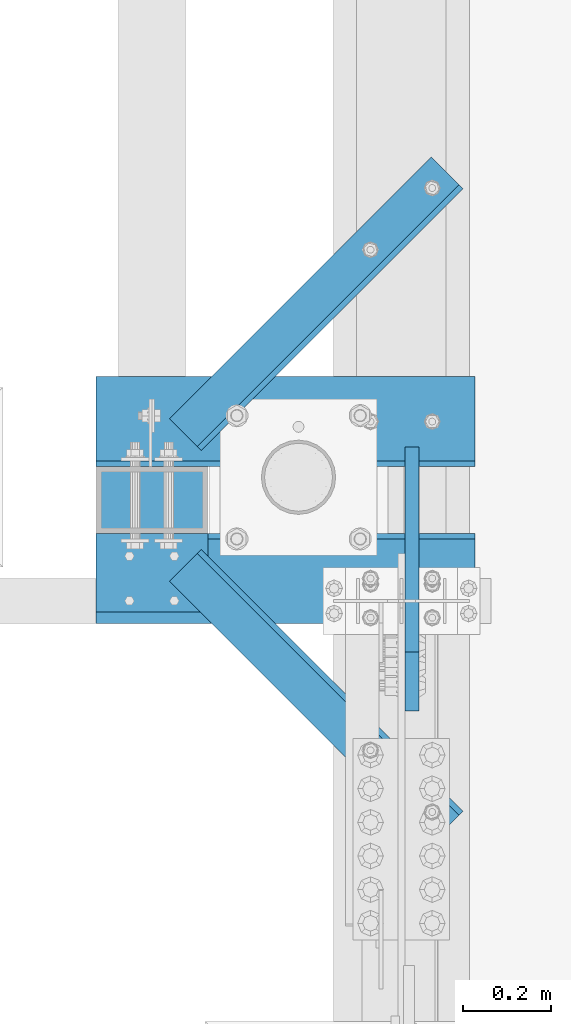
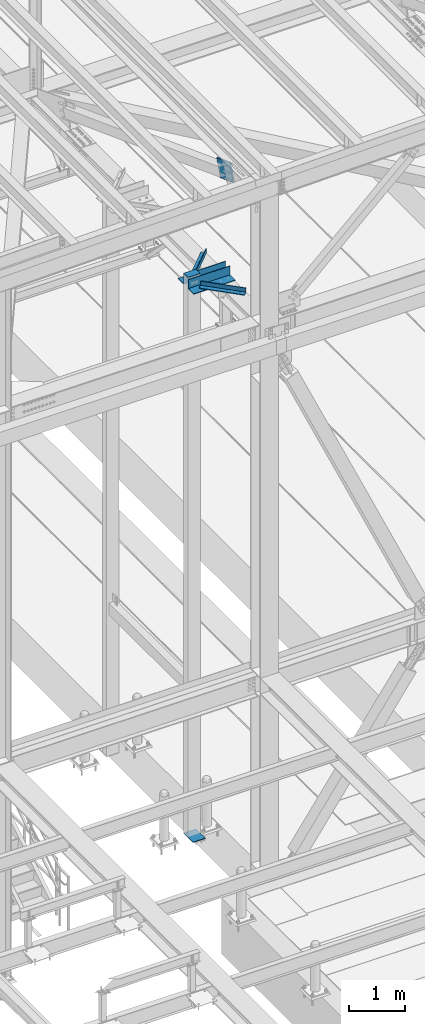
# One storey, part 2028 of 3843: 6 beams, 1 member, 6 elements without a shape of their own.
"""IFC2X3 building model written with IfcOpenShell, lengths in millimetres."""

from ifc_helpers import new_model, si_unit, frame, origin_with_axes, place, context, subcontext, project, spatial, faceted_brep, material, type_object, element, aggregate, save


model = new_model("IFC2X3")

# Units and contexts
model_context = context("Model", 3, precision=1e-05, world=origin_with_axes())
body_context = subcontext(model_context, "Body", "Model", "MODEL_VIEW")
ifc_project = project(units=[si_unit("LENGTHUNIT", "METRE", prefix="MILLI"), si_unit("AREAUNIT", "SQUARE_METRE"), si_unit("VOLUMEUNIT", "CUBIC_METRE"), si_unit("MASSUNIT", "GRAM", prefix="KILO"), si_unit("TIMEUNIT", "SECOND"), si_unit("PLANEANGLEUNIT", "RADIAN"), si_unit("SOLIDANGLEUNIT", "STERADIAN"), si_unit("THERMODYNAMICTEMPERATUREUNIT", "DEGREE_CELSIUS"), si_unit("LUMINOUSINTENSITYUNIT", "LUMEN")], contexts=[model_context])

# Site, building, storey
site_placement = place(None, origin_with_axes())
site = spatial("IfcSite", under=ifc_project, at=site_placement, CompositionType="ELEMENT")
building_placement = place(site_placement, origin_with_axes())
building = spatial("IfcBuilding", under=site, at=building_placement, Name="Undefined", CompositionType="ELEMENT")
storey_placement = place(building_placement, origin_with_axes())
storey = spatial("IfcBuildingStorey", under=building, at=storey_placement, Name="Undefined", CompositionType="ELEMENT", Elevation=0.0)

# Assembly, beam
assembly_1_placement = place(storey_placement, origin_with_axes())
assembly_1 = element("IfcElementAssembly", 1, at=assembly_1_placement, inside=storey, Name="ANGLE", AssemblyPlace="NOTDEFINED", PredefinedType="RIGID_FRAME")
ifc_material = material(Name="STEEL/A572-50")
beam_type_1 = type_object("IfcBeamType", Name="L4X4X1/2", PredefinedType="NOTDEFINED")
beam_1_placement = place(assembly_1_placement, frame((41573.4500000028, 27068.0579510283, 42474.3146705007), z_axis=(0.0, 0.0, 1.0), x_axis=(0.707106781186548, -0.707106781186548, 0.0)))
beam_1 = element("IfcBeam", 2, at=beam_1_placement, type_object=beam_type_1, material=ifc_material, Name="ANGLE", ObjectType="L4X4X1/2", context=body_context, shape_type="Brep", body=[
    faceted_brep([(0.0, 50.8000000000029, -50.8000000000029), (0.0, 50.8000000000029, 50.8000000000029), (838.199999993831, 50.7999999998719, 50.8000000000029), (838.199999993831, 50.7999999998719, -50.8000000000029), (0.0, 38.0999999999985, 50.8000000000029), (838.199999993823, 38.099999999904, 50.8000000000029), (0.0, 38.0999999999985, -38.0999999999985), (838.199999993823, 38.099999999904, -38.0999999999985), (0.0, -50.8000000000029, -38.1000000000058), (838.199999993823, -50.7999999998865, -38.0999999999985), (0.0, -50.8000000000029, -50.8000000000029), (838.199999993823, -50.7999999998865, -50.8000000000029)], [[[0, 1, 2, 3]], [[1, 4, 5, 2]], [[4, 6, 7, 5]], [[6, 8, 9, 7]], [[8, 10, 11, 9]], [[10, 0, 3, 11]], [[5, 7, 9, 11, 3, 2]], [[10, 8, 6, 4, 1, 0]]]),
])
aggregate(assembly_1, [beam_1])

assembly_2_placement = place(storey_placement, origin_with_axes())
assembly_2 = element("IfcElementAssembly", 3, at=assembly_2_placement, inside=storey, Name="ANGLE", AssemblyPlace="NOTDEFINED", PredefinedType="RIGID_FRAME")
beam_2_placement = place(assembly_2_placement, frame((42166.1469039905, 27956.8389529592, 42474.3146705007), z_axis=(0.0, 0.0, 1.0), x_axis=(-0.707106781186549, -0.707106781186546, 0.0)))
beam_2 = element("IfcBeam", 4, at=beam_2_placement, type_object=beam_type_1, material=ifc_material, Name="ANGLE", ObjectType="L4X4X1/2", context=body_context, shape_type="Brep", body=[
    faceted_brep([(0.0, 50.8000000000029, -50.8000000000029), (0.0, 50.8000000000029, 50.8000000000029), (838.199999993831, 50.7999999998719, 50.8000000000029), (838.199999993831, 50.7999999998719, -50.8000000000029), (0.0, 38.0999999999985, 50.8000000000029), (838.199999993823, 38.099999999904, 50.8000000000029), (0.0, 38.0999999999985, -38.0999999999985), (838.199999993823, 38.099999999904, -38.0999999999985), (0.0, -50.8000000000029, -38.1000000000058), (838.199999993823, -50.7999999998865, -38.0999999999985), (0.0, -50.8000000000029, -50.8000000000029), (838.199999993823, -50.7999999998865, -50.8000000000029)], [[[0, 1, 2, 3]], [[1, 4, 5, 2]], [[4, 6, 7, 5]], [[6, 8, 9, 7]], [[8, 10, 11, 9]], [[10, 0, 3, 11]], [[5, 7, 9, 11, 3, 2]], [[10, 8, 6, 4, 1, 0]]]),
])
aggregate(assembly_2, [beam_2])

assembly_3_placement = place(storey_placement, origin_with_axes())
assembly_3 = element("IfcElementAssembly", 5, at=assembly_3_placement, inside=storey, Name="POST", AssemblyPlace="NOTDEFINED", PredefinedType="RIGID_FRAME")
beam_type_2 = type_object("IfcBeamType", PredefinedType="NOTDEFINED")
beam_3_placement = place(assembly_3_placement, frame((41624.25, 27216.1, 42656.125), z_axis=(0.0, 1.0, 0.0), x_axis=(-1.0, 0.0, 0.0)))
beam_3 = element("IfcBeam", 6, at=beam_3_placement, type_object=beam_type_2, material=ifc_material, Name="PLATE", context=body_context, shape_type="Brep", body=[
    faceted_brep([(0.0, 3.17500000000291, -76.2000000000007), (0.0, 3.17499999999927, 76.1999969482422), (254.0, 3.17500000000291, 76.2000000000007), (254.0, 3.17500000000291, -76.2000000000007), (0.0, -3.17499999999927, 76.1999969482422), (254.0, -3.17500000000291, 76.2000000000007), (0.0, -3.17500000000291, -76.2000000000007), (254.0, -3.17500000000291, -76.2000000000007)], [[[0, 1, 2, 3]], [[1, 4, 5, 2]], [[4, 6, 7, 5]], [[6, 0, 3, 7]], [[5, 7, 3, 2]], [[6, 4, 1, 0]]]),
])

# Assembly, member
assembly_4_placement = place(storey_placement, origin_with_axes())
assembly_4 = element("IfcElementAssembly", 7, at=assembly_4_placement, inside=storey, AssemblyPlace="NOTDEFINED", PredefinedType="RIGID_FRAME")
member_type = type_object("IfcMemberType", PredefinedType="NOTDEFINED")
member_placement = place(assembly_4_placement, frame((42086.2125000002, 26805.0065917862, 44893.5775921407), z_axis=(0.0, -0.351612260031988, -0.936145725085148), x_axis=(0.0, 0.936145725085152, -0.351612260031977)))
member = element("IfcMember", 8, at=member_placement, type_object=member_type, material=ifc_material, Name="PLATE", context=body_context, shape_type="Brep", body=[
    faceted_brep([(3.56521923094988e-10, 15.875, -190.500000000146), (-3.61978891305625e-10, 15.875, 190.500000000153), (495.299999995012, 15.875, 190.500000001084), (495.299999995726, 15.875, -190.499999999221), (-3.61978891305625e-10, -15.875, 190.500000000153), (495.299999995012, -15.875, 190.500000001084), (3.56521923094988e-10, -15.875, -190.500000000146), (495.299999995726, -15.875, -190.499999999221)], [[[0, 1, 2, 3]], [[1, 4, 5, 2]], [[4, 6, 7, 5]], [[6, 0, 3, 7]], [[5, 7, 3, 2]], [[6, 4, 1, 0]]]),
])
aggregate(assembly_4, [member])

# Assembly, beam
assembly_5_placement = place(storey_placement, origin_with_axes())
assembly_5 = element("IfcElementAssembly", 9, at=assembly_5_placement, inside=storey, Name="ANGLE", AssemblyPlace="NOTDEFINED", PredefinedType="RIGID_FRAME")
beam_type_3 = type_object("IfcBeamType", Name="L8X8X1/2", PredefinedType="NOTDEFINED")
beam_4_placement = place(assembly_5_placement, frame((41370.25, 27038.3, 42512.4146705007), z_axis=(0.0, 0.0, 1.0), x_axis=(1.0, 0.0, 0.0)))
beam_4 = element("IfcBeam", 10, at=beam_4_placement, type_object=beam_type_3, material=ifc_material, Name="ANGLE", ObjectType="L8X8X1/2", context=body_context, shape_type="Brep", body=[
    faceted_brep([(2.18278728425503e-10, 101.600000000345, -101.600000000006), (2.18278728425503e-10, 101.600000000345, 101.600000000006), (858.837500000009, 101.599999999999, 101.599999999999), (858.837500000009, 101.599999999999, -101.599999999999), (0.0, 88.9000000000015, 101.599999999999), (858.837500000009, 88.9000000000015, 101.599999999999), (0.0, 88.9000000000015, -88.9000000000015), (858.837500000009, 88.9000000000015, -88.9000000000015), (0.0, -101.599999999999, -88.9000000000015), (858.837500000009, -101.599999999999, -88.9000000000015), (-2.25554686039686e-10, -101.600000000329, -101.600000000006), (858.837500000009, -101.599999999999, -101.599999999999)], [[[0, 1, 2, 3]], [[1, 4, 5, 2]], [[4, 6, 7, 5]], [[6, 8, 9, 7]], [[8, 10, 11, 9]], [[10, 0, 3, 11]], [[5, 7, 9, 11, 3, 2]], [[10, 8, 6, 4, 1, 0]]]),
])
aggregate(assembly_5, [beam_4])

assembly_6_placement = place(storey_placement, origin_with_axes())
assembly_6 = element("IfcElementAssembly", 11, at=assembly_6_placement, inside=storey, Name="ANGLE", AssemblyPlace="NOTDEFINED", PredefinedType="RIGID_FRAME")
beam_5_placement = place(assembly_6_placement, frame((42229.0875, 27393.9, 42512.4146705007), z_axis=(0.0, 0.0, 1.0), x_axis=(-1.0, 0.0, 0.0)))
beam_5 = element("IfcBeam", 12, at=beam_5_placement, type_object=beam_type_3, material=ifc_material, Name="ANGLE", ObjectType="L8X8X1/2", context=body_context, shape_type="Brep", body=[
    faceted_brep([(2.18278728425503e-10, 101.600000000345, -101.600000000006), (2.18278728425503e-10, 101.600000000345, 101.600000000006), (858.837500000009, 101.599999999999, 101.599999999999), (858.837500000009, 101.599999999999, -101.599999999999), (0.0, 88.9000000000015, 101.599999999999), (858.837500000009, 88.9000000000015, 101.599999999999), (0.0, 88.9000000000015, -88.9000000000015), (858.837500000009, 88.9000000000015, -88.9000000000015), (0.0, -101.599999999999, -88.9000000000015), (858.837500000009, -101.599999999999, -88.9000000000015), (-2.25554686039686e-10, -101.600000000329, -101.600000000006), (858.837500000009, -101.599999999999, -101.599999999999)], [[[0, 1, 2, 3]], [[1, 4, 5, 2]], [[4, 6, 7, 5]], [[6, 8, 9, 7]], [[8, 10, 11, 9]], [[10, 0, 3, 11]], [[5, 7, 9, 11, 3, 2]], [[10, 8, 6, 4, 1, 0]]]),
])
aggregate(assembly_6, [beam_5])

# Beam
beam_type_4 = type_object("IfcBeamType", PredefinedType="NOTDEFINED")
beam_6_placement = place(assembly_3_placement, frame((41624.25, 27127.1999984741, 30486.35), z_axis=(0.0, -1.0, 0.0), x_axis=(-1.0, 0.0, 0.0)))
beam_6 = element("IfcBeam", 13, at=beam_6_placement, type_object=beam_type_4, material=ifc_material, context=body_context, shape_type="Brep", body=[
    faceted_brep([(-4.07453626394272e-10, 6.34999999999854, -165.099999999366), (3.92901711165905e-10, 6.34999999999854, 165.099999999351), (254.0, 6.34999999999854, 165.099999999999), (254.0, 6.34999999999854, -165.099999999999), (3.92901711165905e-10, -6.34999999999854, 165.099999999351), (254.0, -6.34999999999854, 165.099999999999), (-4.07453626394272e-10, -6.34999999999854, -165.099999999366), (254.0, -6.34999999999854, -165.099999999999)], [[[0, 1, 2, 3]], [[1, 4, 5, 2]], [[4, 6, 7, 5]], [[6, 0, 3, 7]], [[5, 7, 3, 2]], [[6, 4, 1, 0]]]),
])

aggregate(assembly_3, [beam_3, beam_6])

save(model, "model.ifc")
